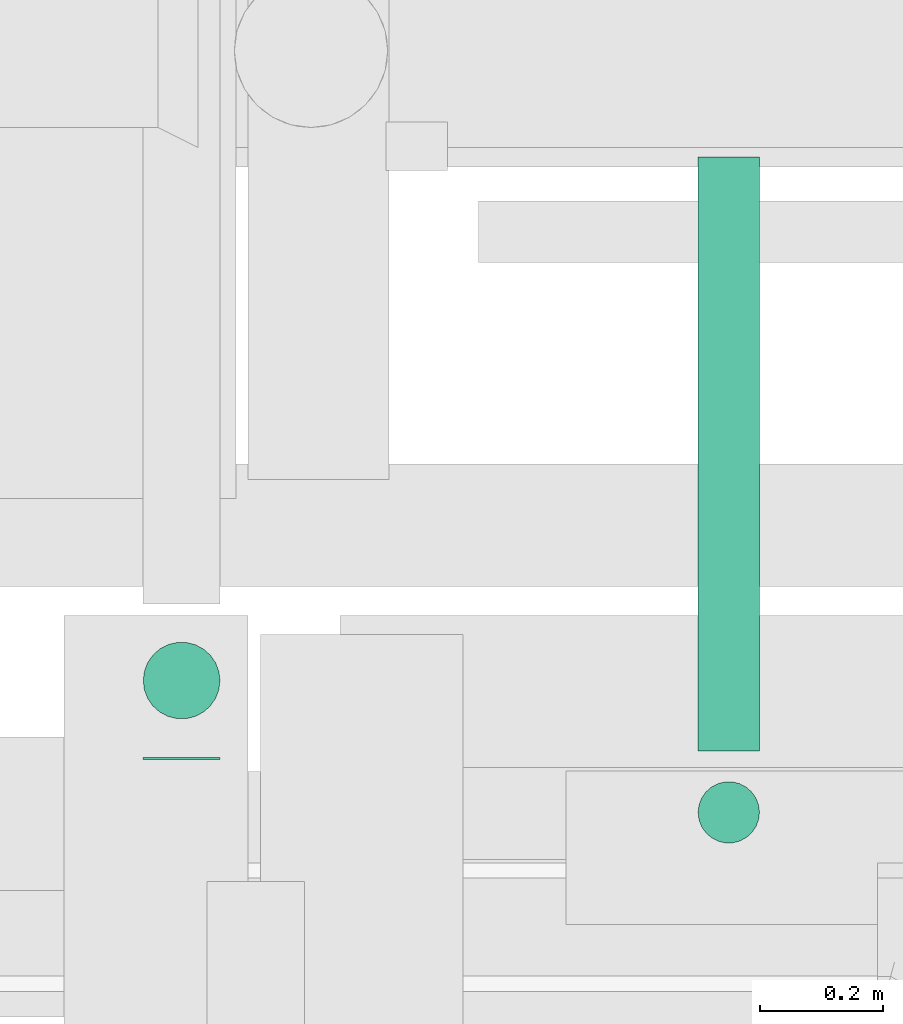
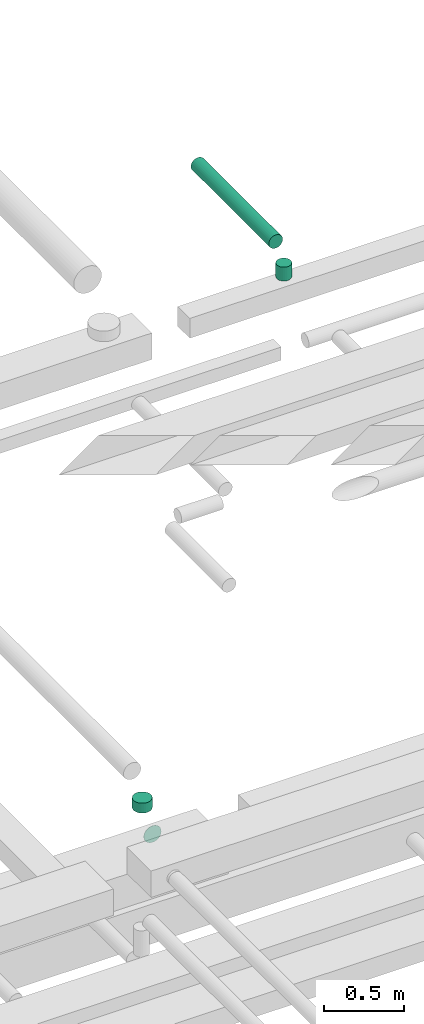
# One storey, part 275 of 337: 4 flow segments.
"""IFC2X3 building model written with IfcOpenShell, lengths in millimetres."""

from ifc_helpers import new_model, entity, si_unit, converted_unit, derived_unit, direction, frame, origin, origin_2d_with_axis, place, context, subcontext, project, spatial, circle, extrude, type_object, element, save


model = new_model("IFC2X3")

# Units and contexts
model_context = context("Model", 3, precision=0.01, world=origin(), true_north=direction((6.12303176911189e-17, 1.0)))
body_context = subcontext(model_context, "Body", "Model", "MODEL_VIEW")
ifc_project = project(units=[si_unit("LENGTHUNIT", "METRE", prefix="MILLI"), si_unit("AREAUNIT", "SQUARE_METRE"), si_unit("VOLUMEUNIT", "CUBIC_METRE"), converted_unit("PLANEANGLEUNIT", "DEGREE", entity("IfcRatioMeasure", 0.0174532925199433), si_unit("PLANEANGLEUNIT", "RADIAN"), dimensions=[0, 0, 0, 0, 0, 0, 0]), si_unit("MASSUNIT", "GRAM", prefix="KILO"), derived_unit("MASSDENSITYUNIT", [(si_unit("MASSUNIT", "GRAM", prefix="KILO"), 1), (si_unit("LENGTHUNIT", "METRE"), -3)]), derived_unit("MOMENTOFINERTIAUNIT", [(si_unit("LENGTHUNIT", "METRE"), 4)]), si_unit("TIMEUNIT", "SECOND"), si_unit("FREQUENCYUNIT", "HERTZ"), si_unit("THERMODYNAMICTEMPERATUREUNIT", "DEGREE_CELSIUS"), derived_unit("THERMALTRANSMITTANCEUNIT", [(si_unit("MASSUNIT", "GRAM", prefix="KILO"), 1), (si_unit("THERMODYNAMICTEMPERATUREUNIT", "KELVIN"), -1), (si_unit("TIMEUNIT", "SECOND"), -3)]), derived_unit("VOLUMETRICFLOWRATEUNIT", [(si_unit("LENGTHUNIT", "METRE"), 3), (si_unit("TIMEUNIT", "SECOND"), -1)]), derived_unit("MASSFLOWRATEUNIT", [(si_unit("MASSUNIT", "GRAM", prefix="KILO"), 1), (si_unit("TIMEUNIT", "SECOND"), -1)]), derived_unit("ROTATIONALFREQUENCYUNIT", [(si_unit("TIMEUNIT", "SECOND"), -1)]), si_unit("ELECTRICCURRENTUNIT", "AMPERE"), si_unit("ELECTRICVOLTAGEUNIT", "VOLT"), si_unit("POWERUNIT", "WATT"), si_unit("FORCEUNIT", "NEWTON", prefix="KILO"), si_unit("ILLUMINANCEUNIT", "LUX"), si_unit("LUMINOUSFLUXUNIT", "LUMEN"), si_unit("LUMINOUSINTENSITYUNIT", "CANDELA"), derived_unit("USERDEFINED", [(si_unit("MASSUNIT", "GRAM", prefix="KILO"), -1), (si_unit("LENGTHUNIT", "METRE"), -2), (si_unit("TIMEUNIT", "SECOND"), 3), (si_unit("LUMINOUSFLUXUNIT", "LUMEN"), 1)]), derived_unit("LINEARVELOCITYUNIT", [(si_unit("LENGTHUNIT", "METRE"), 1), (si_unit("TIMEUNIT", "SECOND"), -1)]), si_unit("PRESSUREUNIT", "PASCAL"), derived_unit("USERDEFINED", [(si_unit("LENGTHUNIT", "METRE"), -2), (si_unit("MASSUNIT", "GRAM", prefix="KILO"), 1), (si_unit("TIMEUNIT", "SECOND"), -2)]), derived_unit("LINEARFORCEUNIT", [(si_unit("MASSUNIT", "GRAM", prefix="KILO"), 1), (si_unit("LENGTHUNIT", "METRE"), 1), (si_unit("TIMEUNIT", "SECOND"), -2), (si_unit("LENGTHUNIT", "METRE"), -1)]), derived_unit("PLANARFORCEUNIT", [(si_unit("MASSUNIT", "GRAM", prefix="KILO"), 1), (si_unit("LENGTHUNIT", "METRE"), 1), (si_unit("TIMEUNIT", "SECOND"), -2), (si_unit("LENGTHUNIT", "METRE"), -2)])], contexts=[model_context])

# Site, building, storey
site_placement = place(None, origin())
site = spatial("IfcSite", under=ifc_project, at=site_placement, CompositionType="ELEMENT")
building_placement = place(site_placement, origin())
building = spatial("IfcBuilding", under=site, at=building_placement, CompositionType="ELEMENT")
storey_placement = place(building_placement, origin())
storey = spatial("IfcBuildingStorey", under=building, at=storey_placement, CompositionType="ELEMENT", Elevation=0.0)

# Flow segments
duct_segment_type = type_object("IfcDuctSegmentType", PredefinedType="NOTDEFINED")
flow_segment_1_placement = place(storey_placement, frame((41985.29, 16233.48, 19098.4)))
element("IfcFlowSegment", 1, at=flow_segment_1_placement, inside=storey, type_object=duct_segment_type, context=body_context, shape_type="SweptSolid", body=[
    extrude(circle(Radius=50.0, at=origin_2d_with_axis()), frame((51.6, 0.0, 51.6), z_axis=(0.0, 1.0, 0.0), x_axis=(-1.0, 0.0, 0.0)), (0.0, 0.0, 1.0), 967.500000000003),
])
flow_segment_2_placement = place(storey_placement, frame((41985.29, 16081.89, 18945.0)))
element("IfcFlowSegment", 2, at=flow_segment_2_placement, inside=storey, type_object=duct_segment_type, context=body_context, shape_type="SweptSolid", body=[
    extrude(circle(Radius=50.0, at=origin_2d_with_axis()), frame((51.6, 51.6, 0.0)), (0.0, 0.0, 1.0), 105.003551488331),
])
flow_segment_3_placement = place(storey_placement, frame((41081.37, 16220.0, 14910.9)))
element("IfcFlowSegment", 3, at=flow_segment_3_placement, inside=storey, type_object=duct_segment_type, context=body_context, shape_type="SweptSolid", body=[
    extrude(circle(Radius=62.5, at=origin_2d_with_axis()), frame((64.1, 0.0, 64.1), z_axis=(0.0, 1.0, 0.0), x_axis=(1.0, 0.0, 0.0)), (0.0, 0.0, 1.0), 3.28852730133407),
])
flow_segment_4_placement = place(storey_placement, frame((41081.37, 16284.19, 15100.0)))
element("IfcFlowSegment", 4, at=flow_segment_4_placement, inside=storey, type_object=duct_segment_type, context=body_context, shape_type="SweptSolid", body=[
    extrude(circle(Radius=62.5, at=origin_2d_with_axis()), frame((64.1, 64.1, 0.0)), (0.0, 0.0, 1.0), 75.0000028020273),
])

save(model, "model.ifc")
